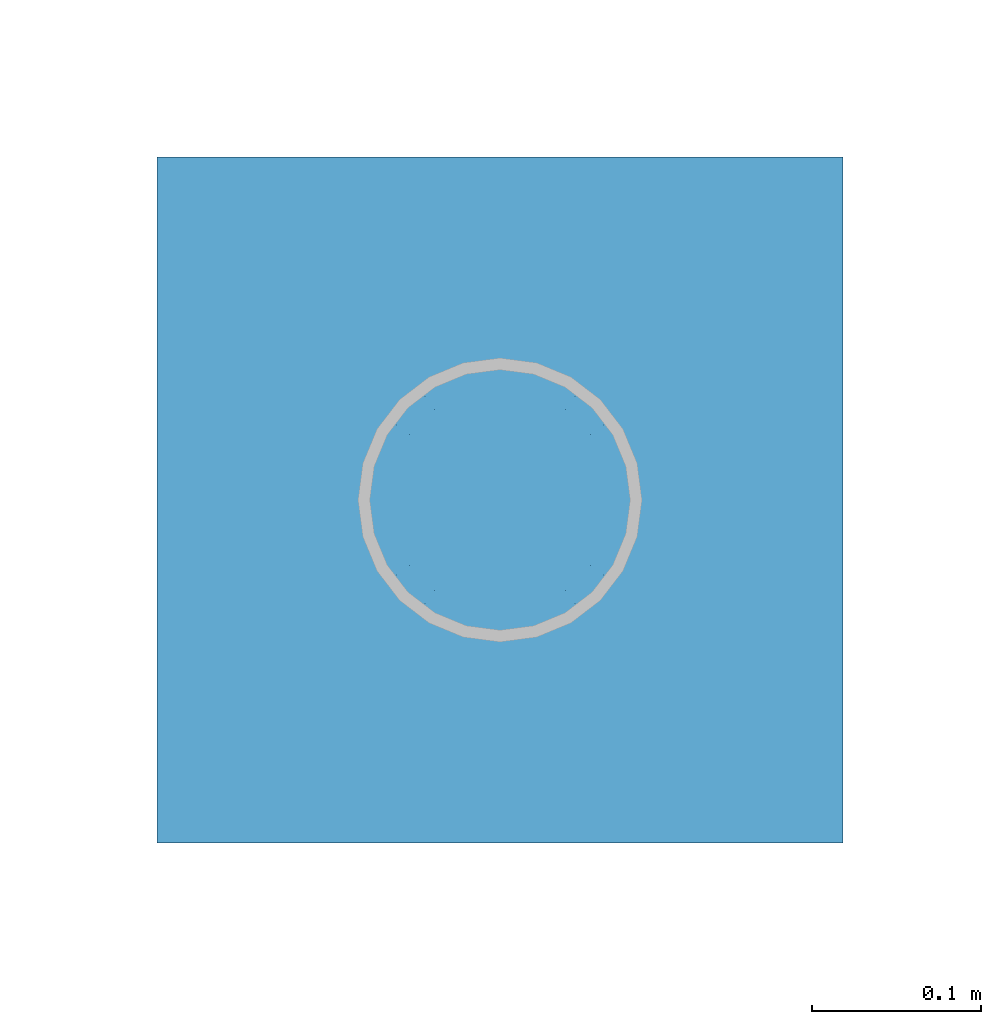
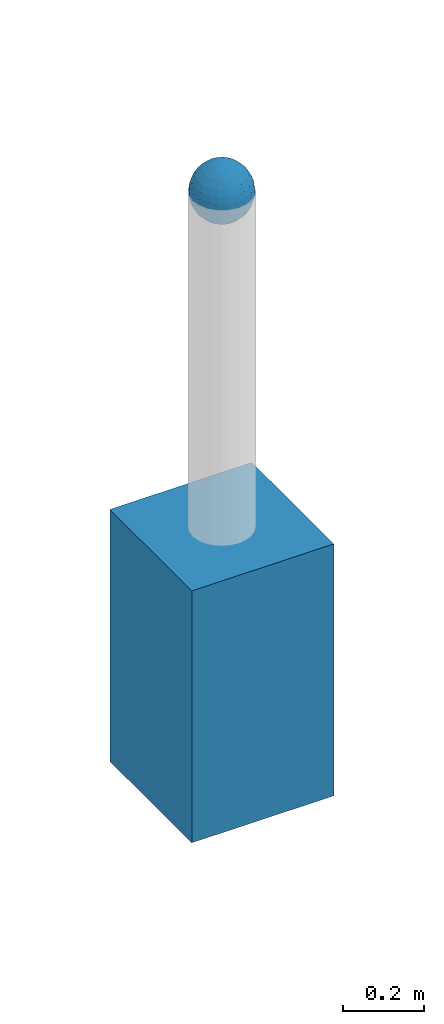
# One storey, part 1517 of 3843: 2 columns, 2 elements without a shape of their own.
"""IFC2X3 building model written with IfcOpenShell, lengths in millimetres."""

from ifc_helpers import new_model, si_unit, frame, origin_with_axes, place, context, subcontext, project, spatial, faceted_brep, material, type_object, element, aggregate, save


model = new_model("IFC2X3")

# Units and contexts
model_context = context("Model", 3, precision=1e-05, world=origin_with_axes())
body_context = subcontext(model_context, "Body", "Model", "MODEL_VIEW")
ifc_project = project(units=[si_unit("LENGTHUNIT", "METRE", prefix="MILLI"), si_unit("AREAUNIT", "SQUARE_METRE"), si_unit("VOLUMEUNIT", "CUBIC_METRE"), si_unit("MASSUNIT", "GRAM", prefix="KILO"), si_unit("TIMEUNIT", "SECOND"), si_unit("PLANEANGLEUNIT", "RADIAN"), si_unit("SOLIDANGLEUNIT", "STERADIAN"), si_unit("THERMODYNAMICTEMPERATUREUNIT", "DEGREE_CELSIUS"), si_unit("LUMINOUSINTENSITYUNIT", "LUMEN")], contexts=[model_context])

# Site, building, storey
site_placement = place(None, origin_with_axes())
site = spatial("IfcSite", under=ifc_project, at=site_placement, CompositionType="ELEMENT")
building_placement = place(site_placement, origin_with_axes())
building = spatial("IfcBuilding", under=site, at=building_placement, Name="Undefined", CompositionType="ELEMENT")
storey_placement = place(building_placement, origin_with_axes())
storey = spatial("IfcBuildingStorey", under=building, at=storey_placement, Name="Undefined", CompositionType="ELEMENT", Elevation=0.0)

# Assembly, column
assembly_1_placement = place(storey_placement, origin_with_axes())
assembly_1 = element("IfcElementAssembly", 1, at=assembly_1_placement, inside=storey, Name="CONC_COL.", AssemblyPlace="NOTDEFINED", PredefinedType="REINFORCEMENT_UNIT")
ifc_material_1 = material(Name="CONCRETE/3000")
column_type_1 = type_object("IfcColumnType", PredefinedType="NOTDEFINED")
column_1_placement = place(assembly_1_placement, frame((15156.5360868275, 56695.0724794865, 29718.0), z_axis=(-1.0, 0.0, 0.0), x_axis=(0.0, 0.0, 1.0)))
column_1 = element("IfcColumn", 2, at=column_1_placement, type_object=column_type_1, material=ifc_material_1, Name="CONC_COL.", context=body_context, shape_type="Brep", body=[
    faceted_brep([(0.0, 203.199999999997, -203.200000000001), (0.0, 203.199999999997, 203.200000000001), (762.0, 203.199999999997, 203.200000000001), (762.0, 203.199999999997, -203.200000000001), (0.0, -203.199999999997, 203.200000000001), (762.0, -203.199999999997, 203.200000000001), (0.0, -203.199999999997, -203.200000000001), (762.0, -203.199999999997, -203.200000000001)], [[[0, 1, 2, 3]], [[1, 4, 5, 2]], [[4, 6, 7, 5]], [[6, 0, 3, 7]], [[5, 7, 3, 2]], [[6, 4, 1, 0]]]),
])
aggregate(assembly_1, [column_1])

assembly_2_placement = place(storey_placement, origin_with_axes())
assembly_2 = element("IfcElementAssembly", 3, at=assembly_2_placement, inside=storey, Name="CONC. FILL", AssemblyPlace="NOTDEFINED", PredefinedType="REINFORCEMENT_UNIT")
ifc_material_2 = material(Name="CONCRETE/1500")
column_type_2 = type_object("IfcColumnType", PredefinedType="NOTDEFINED")
column_2_placement = place(assembly_2_placement, frame((15156.5360868275, 56695.0724794865, 31411.8625), z_axis=(-1.0, 0.0, 0.0), x_axis=(0.0, 0.0, 1.0)))
column_2 = element("IfcColumn", 4, at=column_2_placement, type_object=column_type_2, material=ifc_material_2, Name="CONC. FILL", context=body_context, shape_type="Brep", body=[
    faceted_brep([(0.0, 0.0, 2.0), (0.0, -0.619999999995343, 1.89999999999964), (3.36549999999988, -7.1422259999963, 21.9814139999999), (3.36549999999988, 0.0, 23.1139999999996), (0.0, -1.17999999999302, 1.6200000000008), (3.36549999999988, -13.5910319999966, 18.6992260000006), (0.0, -1.61999999999534, 1.18000000000029), (3.36549999999988, -18.699225999997, 13.5910320000003), (0.0, -1.89999999999418, 0.6200000000008), (3.36549999999988, -21.9814139999944, 7.14222599999994), (0.0, -2.0, 0.0), (3.36549999999988, -23.1140000000014, 0.0), (0.0, -1.89999999999418, -0.6200000000008), (3.36549999999988, -21.9814139999944, -7.14222599999994), (0.0, -1.61999999999534, -1.18000000000029), (3.36549999999988, -18.699225999997, -13.5910320000003), (0.0, -1.17999999999302, -1.6200000000008), (3.36549999999988, -13.5910319999966, -18.6992260000006), (0.0, -0.619999999995343, -1.89999999999964), (3.36549999999988, -7.1422259999963, -21.9814139999999), (0.0, 0.0, -2.0), (3.36549999999988, 0.0, -23.1139999999996), (0.0, 0.619999999995343, -1.89999999999964), (3.36549999999988, 7.1422259999963, -21.9814139999999), (0.0, 1.17999999999302, -1.6200000000008), (3.36549999999988, 13.5910319999966, -18.6992260000006), (0.0, 1.61999999999534, -1.18000000000029), (3.36549999999988, 18.699225999997, -13.5910320000003), (0.0, 1.89999999999418, -0.6200000000008), (3.36549999999988, 21.9814139999944, -7.14222599999994), (0.0, 2.0, 0.0), (3.36549999999988, 23.1140000000014, 0.0), (0.0, 1.89999999999418, 0.6200000000008), (3.36549999999988, 21.9814139999944, 7.14222599999994), (0.0, 1.61999999999534, 1.18000000000029), (3.36549999999988, 18.699225999997, 13.5910320000003), (0.0, 1.17999999999302, 1.6200000000008), (3.36549999999988, 13.5910319999966, 18.6992260000006), (0.0, 0.619999999995343, 1.89999999999964), (3.36549999999988, 7.1422259999963, 21.9814139999999), (8.41374999999971, -11.1214661999984, 34.2282018000005), (8.41374999999971, 0.0, 35.9917999999998), (8.41374999999971, -21.1631784000056, 29.1173662000001), (8.41374999999971, -29.1173661999928, 21.1631784000001), (8.41374999999971, -34.2282017999969, 11.1214662000002), (8.41374999999971, -35.9918000000034, 0.0), (8.41374999999971, -34.2282017999969, -11.1214662000002), (8.41374999999971, -29.1173661999928, -21.1631784000001), (8.41374999999971, -21.1631784000056, -29.1173662000001), (8.41374999999971, -11.1214661999984, -34.2282018000005), (8.41374999999971, 0.0, -35.9917999999998), (8.41374999999971, 11.1214661999984, -34.2282018000005), (8.41374999999971, 21.1631784000056, -29.1173662000001), (8.41374999999971, 29.1173661999928, -21.1631784000001), (8.41374999999971, 34.2282017999969, -11.1214662000002), (8.41374999999971, 35.9918000000034, 0.0), (8.41374999999971, 34.2282017999969, 11.1214662000002), (8.41374999999971, 29.1173661999928, 21.1631784000001), (8.41374999999971, 21.1631784000056, 29.1173662000001), (8.41374999999971, 11.1214661999984, 34.2282018000005), (16.8274999999994, -15.3047700000025, 47.1030300000002), (16.8274999999994, 0.0, 49.5300000000007), (16.8274999999994, -29.1236400000053, 40.0697700000001), (16.8274999999994, -40.0697700000019, 29.1236399999998), (16.8274999999994, -47.1030299999984, 15.3047700000006), (16.8274999999994, -49.5299999999988, 0.0), (16.8274999999994, -47.1030299999984, -15.3047700000006), (16.8274999999994, -40.0697700000019, -29.1236399999998), (16.8274999999994, -29.1236400000053, -40.0697700000001), (16.8274999999994, -15.3047700000025, -47.1030300000002), (16.8274999999994, 0.0, -49.5300000000007), (16.8274999999994, 15.3047700000025, -47.1030300000002), (16.8274999999994, 29.1236400000053, -40.0697700000001), (16.8274999999994, 40.0697700000019, -29.1236399999998), (16.8274999999994, 47.1030299999984, -15.3047700000006), (16.8274999999994, 49.5299999999988, 0.0), (16.8274999999994, 47.1030299999984, 15.3047700000006), (16.8274999999994, 40.0697700000019, 29.1236399999998), (16.8274999999994, 29.1236400000053, 40.0697700000001), (16.8274999999994, 15.3047700000025, 47.1030300000002), (33.6549999999988, -20.4063599999936, 62.8040400000009), (33.6549999999988, 0.0, 66.0400000000009), (33.6549999999988, -38.831520000007, 53.4263599999995), (33.6549999999988, -53.4263599999977, 38.8315199999997), (33.6549999999988, -62.8040400000027, 20.4063600000009), (33.6549999999988, -66.0399999999936, 0.0), (33.6549999999988, -62.8040400000027, -20.4063600000009), (33.6549999999988, -53.4263599999977, -38.8315199999997), (33.6549999999988, -38.831520000007, -53.4263599999995), (33.6549999999988, -20.4063599999936, -62.8040400000009), (33.6549999999988, 0.0, -66.0400000000009), (33.6549999999988, 20.4063599999936, -62.8040400000009), (33.6549999999988, 38.831520000007, -53.4263599999995), (33.6549999999988, 53.4263599999977, -38.8315199999997), (33.6549999999988, 62.8040400000027, -20.4063600000009), (33.6549999999988, 66.0399999999936, 0.0), (33.6549999999988, 62.8040400000027, 20.4063600000009), (33.6549999999988, 53.4263599999977, 38.8315199999997), (33.6549999999988, 38.831520000007, 53.4263599999995), (33.6549999999988, 20.4063599999936, 62.8040400000009), (50.4824999999983, -23.3907901500061, 71.9891308499991), (50.4824999999983, 0.0, 75.6983500000006), (50.4824999999983, -44.5106298000028, 61.23996515), (50.4824999999983, -61.2399651500018, 44.5106297999992), (50.4824999999983, -71.9891308499937, 23.3907901500006), (50.4824999999983, -75.698350000006, 0.0), (50.4824999999983, -71.9891308499937, -23.3907901500006), (50.4824999999983, -61.2399651500018, -44.5106297999992), (50.4824999999983, -44.5106298000028, -61.23996515), (50.4824999999983, -23.3907901500061, -71.9891308499991), (50.4824999999983, 0.0, -75.6983500000006), (50.4824999999983, 23.3907901500061, -71.9891308499991), (50.4824999999983, 44.5106298000028, -61.23996515), (50.4824999999983, 61.2399651500018, -44.5106297999992), (50.4824999999983, 71.9891308499937, -23.3907901500006), (50.4824999999983, 75.698350000006, 0.0), (50.4824999999983, 71.9891308499937, 23.3907901500006), (50.4824999999983, 61.2399651500018, 44.5106297999992), (50.4824999999983, 44.5106298000028, 61.23996515), (50.4824999999983, 23.3907901500061, 71.9891308499991), (67.3099999999977, -24.9977910000016, 76.9349490000004), (67.3099999999977, 0.0, 80.8989999999994), (67.3099999999977, -47.5686120000028, 65.4472910000004), (67.3099999999977, -65.447291000004, 47.5686119999991), (67.3099999999977, -76.9349490000022, 24.9977909999998), (67.3099999999977, -80.8990000000049, 0.0), (67.3099999999977, -76.9349490000022, -24.9977909999998), (67.3099999999977, -65.447291000004, -47.5686119999991), (67.3099999999977, -47.5686120000028, -65.4472910000004), (67.3099999999977, -24.9977910000016, -76.9349490000004), (67.3099999999977, 0.0, -80.8989999999994), (67.3099999999977, 24.9977910000016, -76.9349490000004), (67.3099999999977, 47.5686120000028, -65.4472910000004), (67.3099999999977, 65.447291000004, -47.5686119999991), (67.3099999999977, 76.9349490000022, -24.9977909999998), (67.3099999999977, 80.8990000000049, 0.0), (67.3099999999977, 76.9349490000022, 24.9977909999998), (67.3099999999977, 65.447291000004, 47.5686119999991), (67.3099999999977, 47.5686120000028, 65.4472910000004), (67.3099999999977, 24.9977910000016, 76.9349490000004), (84.1374999999935, -25.5079499999993, 78.5050499999998), (84.1374999999935, 0.0, 82.5499999999993), (84.1374999999935, -48.5393999999942, 66.7829500000007), (84.1374999999935, -66.7829499999934, 48.5393999999997), (84.1374999999935, -78.505050000007, 25.5079499999993), (84.1374999999935, -82.5500000000029, 0.0), (84.1374999999935, -78.505050000007, -25.5079499999993), (84.1374999999935, -66.7829499999934, -48.5393999999997), (84.1374999999935, -48.5393999999942, -66.7829500000007), (84.1374999999935, -25.5079499999993, -78.5050499999998), (84.1374999999935, 0.0, -82.5499999999993), (84.1374999999935, 25.5079499999993, -78.5050499999998), (84.1374999999935, 48.5393999999942, -66.7829500000007), (84.1374999999935, 66.7829499999934, -48.5393999999997), (84.1374999999935, 78.505050000007, -25.5079499999993), (84.1374999999935, 82.5500000000029, 0.0), (84.1374999999935, 78.505050000007, 25.5079499999993), (84.1374999999935, 66.7829499999934, 48.5393999999997), (84.1374999999935, 48.5393999999942, 66.7829500000007), (84.1374999999935, 25.5079499999993, 78.5050499999998), (100.964999999993, -24.9977910000016, 76.9349490000004), (100.964999999993, 0.0, 80.8989999999994), (100.964999999993, -47.5686120000028, 65.4472910000004), (100.964999999993, -65.447291000004, 47.5686119999991), (100.964999999993, -76.9349490000022, 24.9977909999998), (100.964999999993, -80.8990000000049, 0.0), (100.964999999993, -76.9349490000022, -24.9977909999998), (100.964999999993, -65.447291000004, -47.5686119999991), (100.964999999993, -47.5686120000028, -65.4472910000004), (100.964999999993, -24.9977910000016, -76.9349490000004), (100.964999999993, 0.0, -80.8989999999994), (100.964999999993, 24.9977910000016, -76.9349490000004), (100.964999999993, 47.5686120000028, -65.4472910000004), (100.964999999993, 65.447291000004, -47.5686119999991), (100.964999999993, 76.9349490000022, -24.9977909999998), (100.964999999993, 80.8990000000049, 0.0), (100.964999999993, 76.9349490000022, 24.9977909999998), (100.964999999993, 65.447291000004, 47.5686119999991), (100.964999999993, 47.5686120000028, 65.4472910000004), (100.964999999993, 24.9977910000016, 76.9349490000004), (117.792499999992, -23.3907901500061, 71.9891308499991), (117.792499999992, 0.0, 75.6983500000006), (117.792499999992, -44.5106298000028, 61.23996515), (117.792499999992, -61.2399651500018, 44.5106297999992), (117.792499999992, -71.9891308499937, 23.3907901500006), (117.792499999992, -75.698350000006, 0.0), (117.792499999992, -71.9891308499937, -23.3907901500006), (117.792499999992, -61.2399651500018, -44.5106297999992), (117.792499999992, -44.5106298000028, -61.23996515), (117.792499999992, -23.3907901500061, -71.9891308499991), (117.792499999992, 0.0, -75.6983500000006), (117.792499999992, 23.3907901500061, -71.9891308499991), (117.792499999992, 44.5106298000028, -61.23996515), (117.792499999992, 61.2399651500018, -44.5106297999992), (117.792499999992, 71.9891308499937, -23.3907901500006), (117.792499999992, 75.698350000006, 0.0), (117.792499999992, 71.9891308499937, 23.3907901500006), (117.792499999992, 61.2399651500018, 44.5106297999992), (117.792499999992, 44.5106298000028, 61.23996515), (117.792499999992, 23.3907901500061, 71.9891308499991), (134.619999999992, -20.4063599999936, 62.8040400000009), (134.619999999992, 0.0, 66.0400000000009), (134.619999999992, -38.831520000007, 53.4263599999995), (134.619999999992, -53.4263599999977, 38.8315199999997), (134.619999999992, -62.8040400000027, 20.4063600000009), (134.619999999992, -66.0399999999936, 0.0), (134.619999999992, -62.8040400000027, -20.4063600000009), (134.619999999992, -53.4263599999977, -38.8315199999997), (134.619999999992, -38.831520000007, -53.4263599999995), (134.619999999992, -20.4063599999936, -62.8040400000009), (134.619999999992, 0.0, -66.0400000000009), (134.619999999992, 20.4063599999936, -62.8040400000009), (134.619999999992, 38.831520000007, -53.4263599999995), (134.619999999992, 53.4263599999977, -38.8315199999997), (134.619999999992, 62.8040400000027, -20.4063600000009), (134.619999999992, 66.0399999999936, 0.0), (134.619999999992, 62.8040400000027, 20.4063600000009), (134.619999999992, 53.4263599999977, 38.8315199999997), (134.619999999992, 38.831520000007, 53.4263599999995), (134.619999999992, 20.4063599999936, 62.8040400000009), (151.447499999991, -15.3047700000025, 47.1030300000002), (151.447499999991, 0.0, 49.5300000000007), (151.447499999991, -29.1236400000053, 40.0697700000001), (151.447499999991, -40.0697700000019, 29.1236399999998), (151.447499999991, -47.1030299999984, 15.3047700000006), (151.447499999991, -49.5299999999988, 0.0), (151.447499999991, -47.1030299999984, -15.3047700000006), (151.447499999991, -40.0697700000019, -29.1236399999998), (151.447499999991, -29.1236400000053, -40.0697700000001), (151.447499999991, -15.3047700000025, -47.1030300000002), (151.447499999991, 0.0, -49.5300000000007), (151.447499999991, 15.3047700000025, -47.1030300000002), (151.447499999991, 29.1236400000053, -40.0697700000001), (151.447499999991, 40.0697700000019, -29.1236399999998), (151.447499999991, 47.1030299999984, -15.3047700000006), (151.447499999991, 49.5299999999988, 0.0), (151.447499999991, 47.1030299999984, 15.3047700000006), (151.447499999991, 40.0697700000019, 29.1236399999998), (151.447499999991, 29.1236400000053, 40.0697700000001), (151.447499999991, 15.3047700000025, 47.1030300000002), (159.861249999991, -11.1214661999984, 34.2282018000005), (159.861249999991, 0.0, 35.9917999999998), (159.861249999991, -21.1631784000056, 29.1173662000001), (159.861249999991, -29.1173661999928, 21.1631784000001), (159.861249999991, -34.2282017999969, 11.1214662000002), (159.861249999991, -35.9918000000034, 0.0), (159.861249999991, -34.2282017999969, -11.1214662000002), (159.861249999991, -29.1173661999928, -21.1631784000001), (159.861249999991, -21.1631784000056, -29.1173662000001), (159.861249999991, -11.1214661999984, -34.2282018000005), (159.861249999991, 0.0, -35.9917999999998), (159.861249999991, 11.1214661999984, -34.2282018000005), (159.861249999991, 21.1631784000056, -29.1173662000001), (159.861249999991, 29.1173661999928, -21.1631784000001), (159.861249999991, 34.2282017999969, -11.1214662000002), (159.861249999991, 35.9918000000034, 0.0), (159.861249999991, 34.2282017999969, 11.1214662000002), (159.861249999991, 29.1173661999928, 21.1631784000001), (159.861249999991, 21.1631784000056, 29.1173662000001), (159.861249999991, 11.1214661999984, 34.2282018000005), (164.909499999991, -7.1422259999963, 21.9814139999999), (164.909499999991, 0.0, 23.1139999999996), (164.909499999991, -13.5910319999966, 18.6992260000006), (164.909499999991, -18.699225999997, 13.5910320000003), (164.909499999991, -21.9814139999944, 7.14222599999994), (164.909499999991, -23.1140000000014, 0.0), (164.909499999991, -21.9814139999944, -7.14222599999994), (164.909499999991, -18.699225999997, -13.5910320000003), (164.909499999991, -13.5910319999966, -18.6992260000006), (164.909499999991, -7.1422259999963, -21.9814139999999), (164.909499999991, 0.0, -23.1139999999996), (164.909499999991, 7.1422259999963, -21.9814139999999), (164.909499999991, 13.5910319999966, -18.6992260000006), (164.909499999991, 18.699225999997, -13.5910320000003), (164.909499999991, 21.9814139999944, -7.14222599999994), (164.909499999991, 23.1140000000014, 0.0), (164.909499999991, 21.9814139999944, 7.14222599999994), (164.909499999991, 18.699225999997, 13.5910320000003), (164.909499999991, 13.5910319999966, 18.6992260000006), (164.909499999991, 7.1422259999963, 21.9814139999999), (168.274999999991, -0.619999999995343, 1.89999999999964), (168.274999999991, 0.0, 2.0), (168.274999999991, -1.17999999999302, 1.6200000000008), (168.274999999991, -1.61999999999534, 1.18000000000029), (168.274999999991, -1.89999999999418, 0.6200000000008), (168.274999999991, -2.0, 0.0), (168.274999999991, -1.89999999999418, -0.6200000000008), (168.274999999991, -1.61999999999534, -1.18000000000029), (168.274999999991, -1.17999999999302, -1.6200000000008), (168.274999999991, -0.619999999995343, -1.89999999999964), (168.274999999991, 0.0, -2.0), (168.274999999991, 0.619999999995343, -1.89999999999964), (168.274999999991, 1.17999999999302, -1.6200000000008), (168.274999999991, 1.61999999999534, -1.18000000000029), (168.274999999991, 1.89999999999418, -0.6200000000008), (168.274999999991, 2.0, 0.0), (168.274999999991, 1.89999999999418, 0.6200000000008), (168.274999999991, 1.61999999999534, 1.18000000000029), (168.274999999991, 1.17999999999302, 1.6200000000008), (168.274999999991, 0.619999999995343, 1.89999999999964)], [[[0, 1, 2, 3]], [[1, 4, 5, 2]], [[4, 6, 7, 5]], [[6, 8, 9, 7]], [[8, 10, 11, 9]], [[10, 12, 13, 11]], [[12, 14, 15, 13]], [[14, 16, 17, 15]], [[16, 18, 19, 17]], [[18, 20, 21, 19]], [[20, 22, 23, 21]], [[22, 24, 25, 23]], [[24, 26, 27, 25]], [[26, 28, 29, 27]], [[28, 30, 31, 29]], [[30, 32, 33, 31]], [[32, 34, 35, 33]], [[34, 36, 37, 35]], [[36, 38, 39, 37]], [[38, 0, 3, 39]], [[38, 36, 34, 32, 30, 28, 26, 24, 22, 20, 18, 16, 14, 12, 10, 8, 6, 4, 1, 0]], [[3, 2, 40, 41]], [[2, 5, 42, 40]], [[5, 7, 43, 42]], [[7, 9, 44, 43]], [[9, 11, 45, 44]], [[11, 13, 46, 45]], [[13, 15, 47, 46]], [[15, 17, 48, 47]], [[17, 19, 49, 48]], [[19, 21, 50, 49]], [[21, 23, 51, 50]], [[23, 25, 52, 51]], [[25, 27, 53, 52]], [[27, 29, 54, 53]], [[29, 31, 55, 54]], [[31, 33, 56, 55]], [[33, 35, 57, 56]], [[35, 37, 58, 57]], [[37, 39, 59, 58]], [[39, 3, 41, 59]], [[41, 40, 60, 61]], [[40, 42, 62, 60]], [[42, 43, 63, 62]], [[43, 44, 64, 63]], [[44, 45, 65, 64]], [[45, 46, 66, 65]], [[46, 47, 67, 66]], [[47, 48, 68, 67]], [[48, 49, 69, 68]], [[49, 50, 70, 69]], [[50, 51, 71, 70]], [[51, 52, 72, 71]], [[52, 53, 73, 72]], [[53, 54, 74, 73]], [[54, 55, 75, 74]], [[55, 56, 76, 75]], [[56, 57, 77, 76]], [[57, 58, 78, 77]], [[58, 59, 79, 78]], [[59, 41, 61, 79]], [[61, 60, 80, 81]], [[60, 62, 82, 80]], [[62, 63, 83, 82]], [[63, 64, 84, 83]], [[64, 65, 85, 84]], [[65, 66, 86, 85]], [[66, 67, 87, 86]], [[67, 68, 88, 87]], [[68, 69, 89, 88]], [[69, 70, 90, 89]], [[70, 71, 91, 90]], [[71, 72, 92, 91]], [[72, 73, 93, 92]], [[73, 74, 94, 93]], [[74, 75, 95, 94]], [[75, 76, 96, 95]], [[76, 77, 97, 96]], [[77, 78, 98, 97]], [[78, 79, 99, 98]], [[79, 61, 81, 99]], [[81, 80, 100, 101]], [[80, 82, 102, 100]], [[82, 83, 103, 102]], [[83, 84, 104, 103]], [[84, 85, 105, 104]], [[85, 86, 106, 105]], [[86, 87, 107, 106]], [[87, 88, 108, 107]], [[88, 89, 109, 108]], [[89, 90, 110, 109]], [[90, 91, 111, 110]], [[91, 92, 112, 111]], [[92, 93, 113, 112]], [[93, 94, 114, 113]], [[94, 95, 115, 114]], [[95, 96, 116, 115]], [[96, 97, 117, 116]], [[97, 98, 118, 117]], [[98, 99, 119, 118]], [[99, 81, 101, 119]], [[101, 100, 120, 121]], [[100, 102, 122, 120]], [[102, 103, 123, 122]], [[103, 104, 124, 123]], [[104, 105, 125, 124]], [[105, 106, 126, 125]], [[106, 107, 127, 126]], [[107, 108, 128, 127]], [[108, 109, 129, 128]], [[109, 110, 130, 129]], [[110, 111, 131, 130]], [[111, 112, 132, 131]], [[112, 113, 133, 132]], [[113, 114, 134, 133]], [[114, 115, 135, 134]], [[115, 116, 136, 135]], [[116, 117, 137, 136]], [[117, 118, 138, 137]], [[118, 119, 139, 138]], [[119, 101, 121, 139]], [[121, 120, 140, 141]], [[120, 122, 142, 140]], [[122, 123, 143, 142]], [[123, 124, 144, 143]], [[124, 125, 145, 144]], [[125, 126, 146, 145]], [[126, 127, 147, 146]], [[127, 128, 148, 147]], [[128, 129, 149, 148]], [[129, 130, 150, 149]], [[130, 131, 151, 150]], [[131, 132, 152, 151]], [[132, 133, 153, 152]], [[133, 134, 154, 153]], [[134, 135, 155, 154]], [[135, 136, 156, 155]], [[136, 137, 157, 156]], [[137, 138, 158, 157]], [[138, 139, 159, 158]], [[139, 121, 141, 159]], [[141, 140, 160, 161]], [[140, 142, 162, 160]], [[142, 143, 163, 162]], [[143, 144, 164, 163]], [[144, 145, 165, 164]], [[145, 146, 166, 165]], [[146, 147, 167, 166]], [[147, 148, 168, 167]], [[148, 149, 169, 168]], [[149, 150, 170, 169]], [[150, 151, 171, 170]], [[151, 152, 172, 171]], [[152, 153, 173, 172]], [[153, 154, 174, 173]], [[154, 155, 175, 174]], [[155, 156, 176, 175]], [[156, 157, 177, 176]], [[157, 158, 178, 177]], [[158, 159, 179, 178]], [[159, 141, 161, 179]], [[161, 160, 180, 181]], [[160, 162, 182, 180]], [[162, 163, 183, 182]], [[163, 164, 184, 183]], [[164, 165, 185, 184]], [[165, 166, 186, 185]], [[166, 167, 187, 186]], [[167, 168, 188, 187]], [[168, 169, 189, 188]], [[169, 170, 190, 189]], [[170, 171, 191, 190]], [[171, 172, 192, 191]], [[172, 173, 193, 192]], [[173, 174, 194, 193]], [[174, 175, 195, 194]], [[175, 176, 196, 195]], [[176, 177, 197, 196]], [[177, 178, 198, 197]], [[178, 179, 199, 198]], [[179, 161, 181, 199]], [[181, 180, 200, 201]], [[180, 182, 202, 200]], [[182, 183, 203, 202]], [[183, 184, 204, 203]], [[184, 185, 205, 204]], [[185, 186, 206, 205]], [[186, 187, 207, 206]], [[187, 188, 208, 207]], [[188, 189, 209, 208]], [[189, 190, 210, 209]], [[190, 191, 211, 210]], [[191, 192, 212, 211]], [[192, 193, 213, 212]], [[193, 194, 214, 213]], [[194, 195, 215, 214]], [[195, 196, 216, 215]], [[196, 197, 217, 216]], [[197, 198, 218, 217]], [[198, 199, 219, 218]], [[199, 181, 201, 219]], [[201, 200, 220, 221]], [[200, 202, 222, 220]], [[202, 203, 223, 222]], [[203, 204, 224, 223]], [[204, 205, 225, 224]], [[205, 206, 226, 225]], [[206, 207, 227, 226]], [[207, 208, 228, 227]], [[208, 209, 229, 228]], [[209, 210, 230, 229]], [[210, 211, 231, 230]], [[211, 212, 232, 231]], [[212, 213, 233, 232]], [[213, 214, 234, 233]], [[214, 215, 235, 234]], [[215, 216, 236, 235]], [[216, 217, 237, 236]], [[217, 218, 238, 237]], [[218, 219, 239, 238]], [[219, 201, 221, 239]], [[221, 220, 240, 241]], [[220, 222, 242, 240]], [[222, 223, 243, 242]], [[223, 224, 244, 243]], [[224, 225, 245, 244]], [[225, 226, 246, 245]], [[226, 227, 247, 246]], [[227, 228, 248, 247]], [[228, 229, 249, 248]], [[229, 230, 250, 249]], [[230, 231, 251, 250]], [[231, 232, 252, 251]], [[232, 233, 253, 252]], [[233, 234, 254, 253]], [[234, 235, 255, 254]], [[235, 236, 256, 255]], [[236, 237, 257, 256]], [[237, 238, 258, 257]], [[238, 239, 259, 258]], [[239, 221, 241, 259]], [[241, 240, 260, 261]], [[240, 242, 262, 260]], [[242, 243, 263, 262]], [[243, 244, 264, 263]], [[244, 245, 265, 264]], [[245, 246, 266, 265]], [[246, 247, 267, 266]], [[247, 248, 268, 267]], [[248, 249, 269, 268]], [[249, 250, 270, 269]], [[250, 251, 271, 270]], [[251, 252, 272, 271]], [[252, 253, 273, 272]], [[253, 254, 274, 273]], [[254, 255, 275, 274]], [[255, 256, 276, 275]], [[256, 257, 277, 276]], [[257, 258, 278, 277]], [[258, 259, 279, 278]], [[259, 241, 261, 279]], [[261, 260, 280, 281]], [[260, 262, 282, 280]], [[262, 263, 283, 282]], [[263, 264, 284, 283]], [[264, 265, 285, 284]], [[265, 266, 286, 285]], [[266, 267, 287, 286]], [[267, 268, 288, 287]], [[268, 269, 289, 288]], [[269, 270, 290, 289]], [[270, 271, 291, 290]], [[271, 272, 292, 291]], [[272, 273, 293, 292]], [[273, 274, 294, 293]], [[274, 275, 295, 294]], [[275, 276, 296, 295]], [[276, 277, 297, 296]], [[277, 278, 298, 297]], [[278, 279, 299, 298]], [[279, 261, 281, 299]], [[282, 283, 284, 285, 286, 287, 288, 289, 290, 291, 292, 293, 294, 295, 296, 297, 298, 299, 281, 280]]]),
])
aggregate(assembly_2, [column_2])

save(model, "model.ifc")
